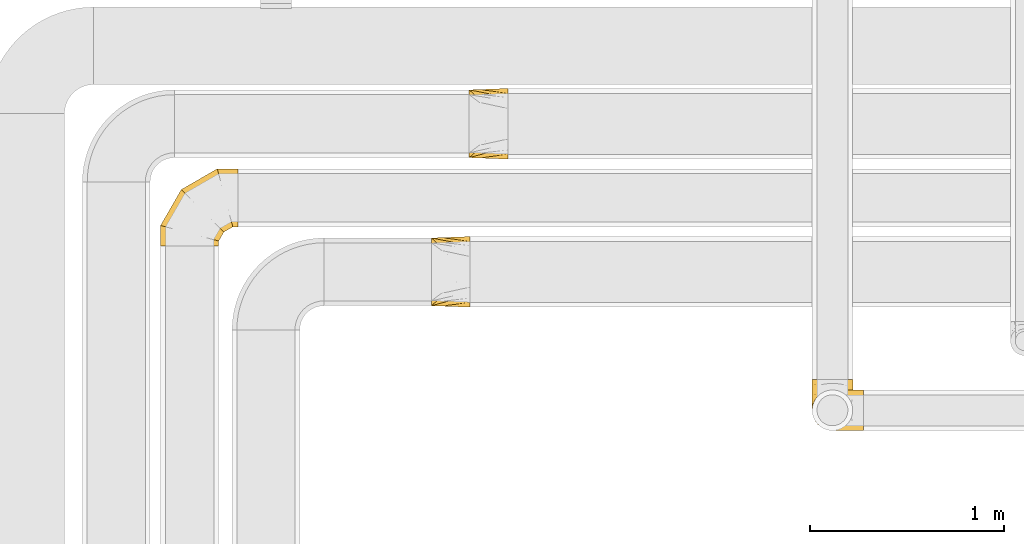
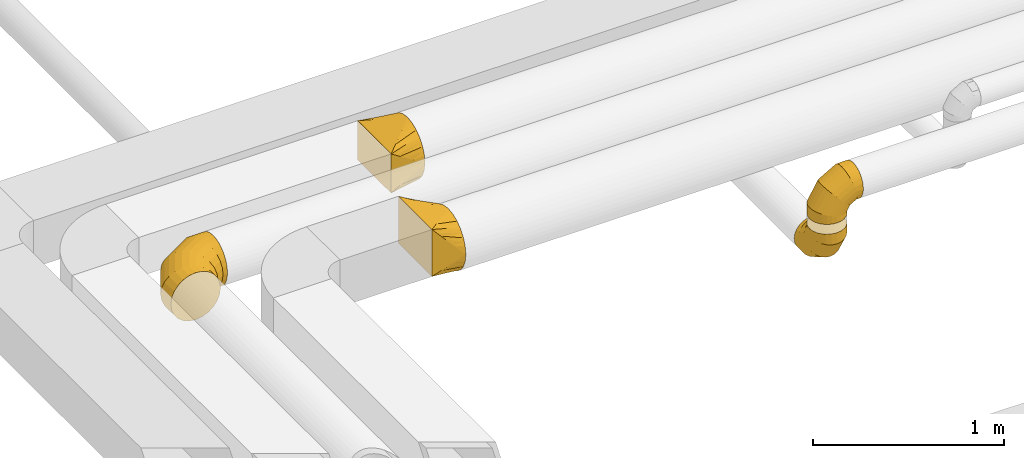
# One storey, part 11 of 92: 5 coverings.
"""IFC2X3 building model written with IfcOpenShell, lengths in millimetres."""

from ifc_helpers import new_model, entity, si_unit, converted_unit, derived_unit, direction, frame, origin, place, context, subcontext, project, spatial, faceted_brep, element, save


model = new_model("IFC2X3")

# Units and contexts
model_context = context("Model", 3, precision=0.01, world=origin(), true_north=direction((6.12303176911189e-17, 1.0)))
body_context = subcontext(model_context, "Body", "Model", "MODEL_VIEW")
ifc_project = project(units=[si_unit("LENGTHUNIT", "METRE", prefix="MILLI"), si_unit("AREAUNIT", "SQUARE_METRE"), si_unit("VOLUMEUNIT", "CUBIC_METRE"), converted_unit("PLANEANGLEUNIT", "DEGREE", entity("IfcRatioMeasure", 0.0174532925199433), si_unit("PLANEANGLEUNIT", "RADIAN"), dimensions=[0, 0, 0, 0, 0, 0, 0]), si_unit("MASSUNIT", "GRAM", prefix="KILO"), derived_unit("MASSDENSITYUNIT", [(si_unit("MASSUNIT", "GRAM", prefix="KILO"), 1), (si_unit("LENGTHUNIT", "METRE"), -3)]), derived_unit("MOMENTOFINERTIAUNIT", [(si_unit("LENGTHUNIT", "METRE"), 4)]), si_unit("TIMEUNIT", "SECOND"), si_unit("FREQUENCYUNIT", "HERTZ"), si_unit("THERMODYNAMICTEMPERATUREUNIT", "DEGREE_CELSIUS"), derived_unit("THERMALTRANSMITTANCEUNIT", [(si_unit("MASSUNIT", "GRAM", prefix="KILO"), 1), (si_unit("THERMODYNAMICTEMPERATUREUNIT", "KELVIN"), -1), (si_unit("TIMEUNIT", "SECOND"), -3)]), derived_unit("VOLUMETRICFLOWRATEUNIT", [(si_unit("LENGTHUNIT", "METRE"), 3), (si_unit("TIMEUNIT", "SECOND"), -1)]), derived_unit("MASSFLOWRATEUNIT", [(si_unit("MASSUNIT", "GRAM", prefix="KILO"), 1), (si_unit("TIMEUNIT", "SECOND"), -1)]), derived_unit("ROTATIONALFREQUENCYUNIT", [(si_unit("TIMEUNIT", "SECOND"), -1)]), si_unit("ELECTRICCURRENTUNIT", "AMPERE"), si_unit("ELECTRICVOLTAGEUNIT", "VOLT"), si_unit("POWERUNIT", "WATT"), si_unit("FORCEUNIT", "NEWTON", prefix="KILO"), si_unit("ILLUMINANCEUNIT", "LUX"), si_unit("LUMINOUSFLUXUNIT", "LUMEN"), si_unit("LUMINOUSINTENSITYUNIT", "CANDELA"), derived_unit("USERDEFINED", [(si_unit("MASSUNIT", "GRAM", prefix="KILO"), -1), (si_unit("LENGTHUNIT", "METRE"), -2), (si_unit("TIMEUNIT", "SECOND"), 3), (si_unit("LUMINOUSFLUXUNIT", "LUMEN"), 1)]), derived_unit("LINEARVELOCITYUNIT", [(si_unit("LENGTHUNIT", "METRE"), 1), (si_unit("TIMEUNIT", "SECOND"), -1)]), si_unit("PRESSUREUNIT", "PASCAL"), derived_unit("USERDEFINED", [(si_unit("LENGTHUNIT", "METRE"), -2), (si_unit("MASSUNIT", "GRAM", prefix="KILO"), 1), (si_unit("TIMEUNIT", "SECOND"), -2)]), derived_unit("LINEARFORCEUNIT", [(si_unit("MASSUNIT", "GRAM", prefix="KILO"), 1), (si_unit("LENGTHUNIT", "METRE"), 1), (si_unit("TIMEUNIT", "SECOND"), -2), (si_unit("LENGTHUNIT", "METRE"), -1)]), derived_unit("PLANARFORCEUNIT", [(si_unit("MASSUNIT", "GRAM", prefix="KILO"), 1), (si_unit("LENGTHUNIT", "METRE"), 1), (si_unit("TIMEUNIT", "SECOND"), -2), (si_unit("LENGTHUNIT", "METRE"), -2)])], contexts=[model_context])

# Site, building, storey
site_placement = place(None, origin())
site = spatial("IfcSite", under=ifc_project, at=site_placement, CompositionType="ELEMENT")
building_placement = place(site_placement, origin())
building = spatial("IfcBuilding", under=site, at=building_placement, CompositionType="ELEMENT")
storey_placement = place(building_placement, frame((0.0, 0.0, 4200.0)))
storey = spatial("IfcBuildingStorey", under=building, at=storey_placement, CompositionType="ELEMENT", Elevation=4200.0)

# Coverings
covering_1_placement = place(storey_placement, frame((25785.03, 14135.4, 2853.4)))
element("IfcCovering", 1, at=covering_1_placement, inside=storey, PredefinedType="INSULATION", context=body_context, shape_type="Brep", body=[
    faceted_brep([(1.6, 106.6, 266.6), (6.73, 74.15, 266.6), (21.65, 44.88, 266.6), (44.88, 21.65, 266.6), (74.15, 6.73, 266.6), (106.6, 1.6, 266.6), (139.04, 6.73, 266.6), (168.31, 21.65, 266.6), (191.54, 44.88, 266.6), (206.46, 74.15, 266.6), (211.6, 106.6, 266.6), (206.46, 139.04, 266.6), (191.54, 168.31, 266.6), (168.31, 191.54, 266.6), (139.04, 206.46, 266.6), (106.6, 211.6, 266.6), (74.15, 206.46, 266.6), (44.88, 191.54, 266.6), (21.65, 168.31, 266.6), (6.73, 139.04, 266.6), (159.1, 266.6, 15.66), (133.77, 266.6, 5.17), (106.6, 266.6, 1.6), (79.42, 266.6, 5.17), (54.1, 266.6, 15.66), (32.35, 266.6, 32.35), (15.66, 266.6, 54.1), (5.17, 266.6, 79.42), (1.6, 266.6, 106.6), (5.17, 266.6, 133.77), (15.66, 266.6, 159.1), (32.35, 266.6, 180.84), (54.1, 266.6, 197.53), (79.42, 266.6, 208.02), (106.6, 266.6, 211.6), (133.77, 266.6, 208.02), (159.1, 266.6, 197.53), (180.84, 266.6, 180.84), (197.53, 266.6, 159.1), (208.02, 266.6, 133.77), (211.6, 266.6, 106.6), (208.02, 266.6, 79.42), (197.53, 266.6, 54.1), (180.84, 266.6, 32.35), (106.6, 195.59, 1.6), (79.42, 196.55, 5.17), (54.1, 199.36, 15.66), (32.35, 203.83, 32.35), (15.66, 209.66, 54.1), (5.17, 216.44, 79.42), (1.6, 223.72, 106.6), (5.17, 231.01, 133.77), (15.66, 237.79, 159.1), (32.35, 243.62, 180.84), (54.1, 248.09, 197.53), (79.42, 250.9, 208.02), (106.6, 251.86, 211.6), (133.77, 250.9, 208.02), (159.1, 248.09, 197.53), (180.84, 243.62, 180.84), (208.02, 231.01, 133.77), (211.6, 223.72, 106.6), (197.53, 237.79, 159.1), (208.02, 216.44, 79.42), (197.53, 209.66, 54.1), (180.84, 203.83, 32.35), (159.1, 199.36, 15.66), (133.77, 196.55, 5.17), (106.6, 72.6, 72.6), (79.42, 75.22, 75.22), (54.1, 82.9, 82.9), (32.35, 95.12, 95.12), (15.66, 111.03, 111.03), (5.17, 129.57, 129.57), (1.6, 149.47, 149.47), (5.17, 169.36, 169.36), (15.66, 187.9, 187.9), (32.35, 203.82, 203.82), (54.1, 216.03, 216.03), (79.42, 223.71, 223.71), (106.6, 226.33, 226.33), (133.77, 223.71, 223.71), (159.1, 216.03, 216.03), (180.84, 203.82, 203.82), (208.02, 169.36, 169.36), (211.6, 149.47, 149.47), (197.53, 187.9, 187.9), (208.02, 129.57, 129.57), (197.53, 111.03, 111.03), (180.84, 95.12, 95.12), (159.1, 82.9, 82.9), (133.77, 75.22, 75.22), (106.6, 1.6, 195.59), (79.42, 5.17, 196.55), (54.1, 15.66, 199.36), (32.35, 32.35, 203.83), (15.66, 54.1, 209.66), (5.17, 79.42, 216.44), (1.6, 106.6, 223.72), (5.17, 133.77, 231.01), (15.66, 159.1, 237.79), (32.35, 180.84, 243.62), (54.1, 197.53, 248.09), (79.42, 208.02, 250.9), (106.6, 211.6, 251.86), (133.77, 208.02, 250.9), (159.1, 197.53, 248.09), (180.84, 180.84, 243.62), (208.02, 133.77, 231.01), (211.6, 106.6, 223.72), (197.53, 159.1, 237.79), (208.02, 79.42, 216.44), (197.53, 54.1, 209.66), (180.84, 32.35, 203.83), (159.1, 15.66, 199.36), (133.77, 5.17, 196.55)], [[[0, 1, 2, 3, 4, 5, 6, 7, 8, 9, 10, 11, 12, 13, 14, 15, 16, 17, 18, 19]], [[20, 21, 22, 23, 24, 25, 26, 27, 28, 29, 30, 31, 32, 33, 34, 35, 36, 37, 38, 39, 40, 41, 42, 43]], [[22, 44, 45, 23]], [[23, 45, 46, 24]], [[24, 46, 47, 25]], [[25, 47, 48, 26]], [[26, 48, 49, 27]], [[50, 28, 27, 49]], [[51, 52, 30, 29]], [[50, 51, 29, 28]], [[53, 31, 30, 52]], [[54, 55, 33, 32]], [[54, 32, 31, 53]], [[56, 34, 33, 55]], [[57, 58, 36, 35]], [[56, 57, 35, 34]], [[37, 36, 58, 59]], [[60, 61, 40, 39]], [[62, 60, 39, 38]], [[59, 62, 38, 37]], [[41, 40, 61, 63]], [[42, 41, 63, 64]], [[64, 65, 43, 42]], [[21, 20, 66, 67]], [[22, 21, 67, 44]], [[65, 66, 20, 43]], [[45, 44, 68, 69]], [[46, 45, 69, 70]], [[70, 71, 47, 46]], [[48, 47, 71, 72]], [[49, 48, 72, 73]], [[50, 49, 73, 74]], [[75, 76, 52, 51]], [[74, 75, 51, 50]], [[53, 52, 76, 77]], [[78, 79, 55, 54]], [[77, 78, 54, 53]], [[56, 55, 79, 80]], [[81, 82, 58, 57]], [[80, 81, 57, 56]], [[59, 58, 82, 83]], [[84, 85, 61, 60]], [[86, 84, 60, 62]], [[83, 86, 62, 59]], [[63, 61, 85, 87]], [[64, 63, 87, 88]], [[65, 64, 88, 89]], [[67, 66, 90, 91]], [[44, 67, 91, 68]], [[89, 90, 66, 65]], [[69, 68, 92, 93]], [[70, 69, 93, 94]], [[94, 95, 71, 70]], [[72, 71, 95, 96]], [[73, 72, 96, 97]], [[74, 73, 97, 98]], [[99, 100, 76, 75]], [[98, 99, 75, 74]], [[77, 76, 100, 101]], [[102, 103, 79, 78]], [[101, 102, 78, 77]], [[80, 79, 103, 104]], [[105, 106, 82, 81]], [[104, 105, 81, 80]], [[83, 82, 106, 107]], [[108, 109, 85, 84]], [[110, 108, 84, 86]], [[107, 110, 86, 83]], [[87, 85, 109, 111]], [[88, 87, 111, 112]], [[89, 88, 112, 113]], [[91, 90, 114, 115]], [[68, 91, 115, 92]], [[113, 114, 90, 89]], [[93, 5, 4]], [[94, 4, 3]], [[5, 93, 92]], [[93, 4, 94]], [[3, 95, 94]], [[96, 2, 1]], [[97, 1, 0]], [[95, 2, 96]], [[96, 1, 97]], [[0, 98, 97]], [[2, 95, 3]], [[99, 0, 19]], [[100, 19, 18]], [[99, 98, 0]], [[100, 99, 19]], [[18, 101, 100]], [[102, 17, 16]], [[103, 16, 15]], [[102, 101, 17]], [[104, 103, 15]], [[102, 16, 103]], [[17, 101, 18]], [[105, 15, 14]], [[106, 14, 13]], [[105, 104, 15]], [[106, 105, 14]], [[13, 107, 106]], [[110, 12, 11]], [[108, 11, 10]], [[110, 107, 12]], [[109, 108, 10]], [[110, 11, 108]], [[12, 107, 13]], [[9, 8, 112]], [[10, 9, 111]], [[10, 111, 109]], [[111, 9, 112]], [[8, 113, 112]], [[114, 7, 6]], [[115, 6, 5]], [[113, 7, 114]], [[115, 114, 6]], [[92, 115, 5]], [[7, 113, 8]]]),
])
covering_2_placement = place(storey_placement, frame((25785.03, 14135.4, 3182.7)))
element("IfcCovering", 2, at=covering_2_placement, inside=storey, PredefinedType="INSULATION", context=body_context, shape_type="Brep", body=[
    faceted_brep([(266.6, 211.6, 160.0), (266.6, 206.46, 192.45), (266.6, 191.54, 221.72), (266.6, 168.31, 244.95), (266.6, 139.04, 259.86), (266.6, 106.6, 265.0), (266.6, 74.15, 259.86), (266.6, 44.88, 244.95), (266.6, 21.65, 221.72), (266.6, 6.73, 192.45), (266.6, 1.6, 160.0), (266.6, 6.73, 127.55), (266.6, 21.65, 98.28), (266.6, 44.88, 75.05), (266.6, 74.15, 60.14), (266.6, 106.6, 55.0), (266.6, 139.04, 60.14), (266.6, 168.31, 75.05), (266.6, 191.54, 98.28), (266.6, 206.46, 127.55), (15.66, 54.1, 0.0), (5.17, 79.42, 0.0), (1.6, 106.6, 0.0), (5.17, 133.77, 0.0), (15.66, 159.1, 0.0), (32.35, 180.84, 0.0), (54.1, 197.53, 0.0), (79.42, 208.02, 0.0), (106.6, 211.6, 0.0), (133.77, 208.02, 0.0), (159.1, 197.53, 0.0), (180.84, 180.84, 0.0), (197.53, 159.1, 0.0), (208.02, 133.77, 0.0), (211.6, 106.6, 0.0), (208.02, 79.42, 0.0), (197.53, 54.1, 0.0), (180.84, 32.35, 0.0), (159.1, 15.66, 0.0), (133.77, 5.17, 0.0), (106.6, 1.6, 0.0), (79.42, 5.17, 0.0), (54.1, 15.66, 0.0), (32.35, 32.35, 0.0), (1.6, 106.6, 71.01), (5.17, 133.77, 70.05), (15.66, 159.1, 67.24), (32.35, 180.84, 62.77), (54.1, 197.53, 56.94), (79.42, 208.02, 50.15), (106.6, 211.6, 42.87), (133.77, 208.02, 35.59), (159.1, 197.53, 28.8), (180.84, 180.84, 22.98), (197.53, 159.1, 18.51), (208.02, 133.77, 15.7), (211.6, 106.6, 14.74), (208.02, 79.42, 15.7), (197.53, 54.1, 18.51), (180.84, 32.35, 22.98), (133.77, 5.17, 35.59), (106.6, 1.6, 42.87), (159.1, 15.66, 28.8), (79.42, 5.17, 50.15), (54.1, 15.66, 56.94), (32.35, 32.35, 62.77), (15.66, 54.1, 67.24), (5.17, 79.42, 70.05), (72.6, 106.6, 193.99), (75.22, 133.77, 191.37), (82.9, 159.1, 183.7), (95.12, 180.84, 171.48), (111.03, 197.53, 155.56), (129.57, 208.02, 137.02), (149.47, 211.6, 117.13), (169.36, 208.02, 97.23), (187.9, 197.53, 78.7), (203.82, 180.84, 62.78), (216.03, 159.1, 50.56), (223.71, 133.77, 42.88), (226.33, 106.6, 40.26), (223.71, 79.42, 42.88), (216.03, 54.1, 50.56), (203.82, 32.35, 62.78), (169.36, 5.17, 97.23), (149.47, 1.6, 117.13), (187.9, 15.66, 78.7), (129.57, 5.17, 137.02), (111.03, 15.66, 155.56), (95.12, 32.35, 171.48), (82.9, 54.1, 183.7), (75.22, 79.42, 191.37), (195.59, 106.6, 265.0), (196.55, 133.77, 261.42), (199.36, 159.1, 250.93), (203.83, 180.84, 234.25), (209.66, 197.53, 212.5), (216.44, 208.02, 187.18), (223.72, 211.6, 160.0), (231.01, 208.02, 132.82), (237.79, 197.53, 107.5), (243.62, 180.84, 85.75), (248.09, 159.1, 69.07), (250.9, 133.77, 58.58), (251.86, 106.6, 55.0), (250.9, 79.42, 58.58), (248.09, 54.1, 69.07), (243.62, 32.35, 85.75), (231.01, 5.17, 132.82), (223.72, 1.6, 160.0), (237.79, 15.66, 107.5), (216.44, 5.17, 187.18), (209.66, 15.66, 212.5), (203.83, 32.35, 234.25), (199.36, 54.1, 250.93), (196.55, 79.42, 261.42)], [[[0, 1, 2, 3, 4, 5, 6, 7, 8, 9, 10, 11, 12, 13, 14, 15, 16, 17, 18, 19]], [[20, 21, 22, 23, 24, 25, 26, 27, 28, 29, 30, 31, 32, 33, 34, 35, 36, 37, 38, 39, 40, 41, 42, 43]], [[22, 44, 45, 23]], [[23, 45, 46, 24]], [[24, 46, 47, 25]], [[25, 47, 48, 26]], [[26, 48, 49, 27]], [[50, 28, 27, 49]], [[51, 52, 30, 29]], [[50, 51, 29, 28]], [[53, 31, 30, 52]], [[54, 55, 33, 32]], [[54, 32, 31, 53]], [[56, 34, 33, 55]], [[57, 58, 36, 35]], [[56, 57, 35, 34]], [[37, 36, 58, 59]], [[60, 61, 40, 39]], [[62, 60, 39, 38]], [[59, 62, 38, 37]], [[41, 40, 61, 63]], [[42, 41, 63, 64]], [[64, 65, 43, 42]], [[21, 20, 66, 67]], [[22, 21, 67, 44]], [[65, 66, 20, 43]], [[45, 44, 68, 69]], [[46, 45, 69, 70]], [[70, 71, 47, 46]], [[48, 47, 71, 72]], [[49, 48, 72, 73]], [[50, 49, 73, 74]], [[75, 76, 52, 51]], [[74, 75, 51, 50]], [[53, 52, 76, 77]], [[78, 79, 55, 54]], [[77, 78, 54, 53]], [[56, 55, 79, 80]], [[81, 82, 58, 57]], [[80, 81, 57, 56]], [[59, 58, 82, 83]], [[84, 85, 61, 60]], [[86, 84, 60, 62]], [[83, 86, 62, 59]], [[63, 61, 85, 87]], [[64, 63, 87, 88]], [[65, 64, 88, 89]], [[67, 66, 90, 91]], [[44, 67, 91, 68]], [[89, 90, 66, 65]], [[69, 68, 92, 93]], [[70, 69, 93, 94]], [[94, 95, 71, 70]], [[72, 71, 95, 96]], [[73, 72, 96, 97]], [[74, 73, 97, 98]], [[99, 100, 76, 75]], [[98, 99, 75, 74]], [[77, 76, 100, 101]], [[102, 103, 79, 78]], [[101, 102, 78, 77]], [[80, 79, 103, 104]], [[105, 106, 82, 81]], [[104, 105, 81, 80]], [[83, 82, 106, 107]], [[108, 109, 85, 84]], [[110, 108, 84, 86]], [[107, 110, 86, 83]], [[87, 85, 109, 111]], [[88, 87, 111, 112]], [[89, 88, 112, 113]], [[91, 90, 114, 115]], [[68, 91, 115, 92]], [[113, 114, 90, 89]], [[93, 5, 4]], [[94, 4, 3]], [[5, 93, 92]], [[93, 4, 94]], [[3, 95, 94]], [[96, 2, 1]], [[97, 1, 0]], [[95, 2, 96]], [[96, 1, 97]], [[0, 98, 97]], [[2, 95, 3]], [[99, 0, 19]], [[100, 19, 18]], [[99, 98, 0]], [[100, 99, 19]], [[18, 101, 100]], [[102, 17, 16]], [[103, 16, 15]], [[102, 101, 17]], [[104, 103, 15]], [[102, 16, 103]], [[17, 101, 18]], [[105, 15, 14]], [[106, 14, 13]], [[105, 104, 15]], [[106, 105, 14]], [[13, 107, 106]], [[110, 12, 11]], [[108, 11, 10]], [[110, 107, 12]], [[109, 108, 10]], [[110, 11, 108]], [[12, 107, 13]], [[9, 8, 112]], [[10, 9, 111]], [[10, 111, 109]], [[111, 9, 112]], [[8, 113, 112]], [[114, 7, 6]], [[115, 6, 5]], [[113, 7, 114]], [[115, 114, 6]], [[92, 115, 5]], [[7, 113, 8]]]),
])
covering_3_placement = place(storey_placement, frame((24015.14, 15537.91, 3115.9)))
element("IfcCovering", 3, at=covering_3_placement, inside=storey, PredefinedType="INSULATION", context=body_context, shape_type="Brep", body=[
    faceted_brep([(200.0, 313.14, 313.14), (200.0, 294.24, 327.64), (200.0, 275.35, 342.14), (200.0, 253.34, 351.26), (200.0, 231.33, 360.38), (200.0, 216.46, 362.33), (200.0, 201.59, 364.29), (200.0, 184.1, 366.6), (200.0, 166.6, 364.29), (200.0, 151.73, 362.33), (200.0, 136.86, 360.38), (200.0, 114.85, 351.26), (200.0, 92.85, 342.14), (200.0, 73.95, 327.64), (200.0, 55.05, 313.14), (200.0, 40.55, 294.24), (200.0, 26.05, 275.35), (200.0, 16.93, 253.34), (200.0, 7.81, 231.33), (200.0, 5.86, 216.46), (200.0, 3.9, 201.59), (200.0, 1.6, 184.1), (200.0, 3.9, 166.6), (200.0, 5.86, 151.73), (200.0, 7.81, 136.86), (200.0, 16.93, 114.85), (200.0, 26.05, 92.85), (200.0, 40.55, 73.95), (200.0, 55.05, 55.05), (200.0, 73.95, 40.55), (200.0, 92.85, 26.05), (200.0, 114.85, 16.93), (200.0, 136.86, 7.81), (200.0, 151.73, 5.86), (200.0, 166.6, 3.9), (200.0, 184.1, 1.6), (200.0, 201.59, 3.9), (200.0, 216.46, 5.86), (200.0, 231.33, 7.81), (200.0, 253.34, 16.93), (200.0, 275.35, 26.05), (200.0, 294.24, 40.55), (200.0, 313.14, 55.05), (200.0, 327.64, 73.95), (200.0, 342.14, 92.85), (200.0, 351.26, 114.85), (200.0, 360.38, 136.86), (200.0, 362.33, 151.73), (200.0, 364.29, 166.6), (200.0, 366.6, 184.1), (200.0, 364.29, 201.59), (200.0, 362.33, 216.46), (200.0, 360.38, 231.33), (200.0, 351.26, 253.34), (200.0, 342.14, 275.35), (200.0, 327.64, 294.24), (0.0, 359.1, 309.1), (0.0, 359.1, 59.1), (0.0, 9.1, 59.1), (0.0, 9.1, 309.1), (128.09, 247.02, 22.27), (104.11, 268.0, 29.16), (78.09, 290.77, 36.65), (100.0, 332.1, 53.28), (26.03, 336.32, 51.61), (52.06, 361.05, 91.63), (26.03, 360.07, 75.36), (78.09, 362.02, 107.9), (104.11, 363.0, 124.17), (128.09, 363.9, 139.15), (176.03, 205.07, 8.49), (152.06, 226.05, 15.38), (152.06, 364.8, 154.13), (176.03, 365.7, 169.11), (52.06, 313.55, 44.13), (26.03, 360.07, 292.83), (52.06, 361.05, 276.56), (78.09, 362.02, 260.29), (104.11, 363.0, 244.02), (128.09, 363.9, 229.04), (152.06, 364.8, 214.06), (176.03, 365.7, 199.08), (100.0, 339.91, 307.1), (52.06, 313.55, 324.06), (26.03, 336.32, 316.58), (78.09, 290.77, 331.54), (104.11, 268.0, 339.03), (128.09, 247.02, 345.92), (152.06, 226.05, 352.81), (176.03, 205.07, 359.7), (26.03, 31.87, 316.58), (52.06, 54.65, 324.06), (78.09, 77.42, 331.54), (104.11, 100.2, 339.03), (128.09, 121.17, 345.92), (152.06, 142.15, 352.81), (176.03, 163.12, 359.7), (100.0, 36.1, 314.91), (52.06, 7.14, 276.56), (26.03, 8.12, 292.83), (78.09, 6.17, 260.29), (104.11, 5.19, 244.02), (128.09, 4.29, 229.04), (152.06, 3.39, 214.06), (176.03, 2.49, 199.08), (26.03, 8.12, 75.36), (52.06, 7.14, 91.63), (78.09, 6.17, 107.9), (104.11, 5.19, 124.17), (128.09, 4.29, 139.15), (152.06, 3.39, 154.13), (176.03, 2.49, 169.11), (100.0, 28.28, 61.1), (52.06, 54.65, 44.13), (26.03, 31.87, 51.61), (78.09, 77.42, 36.65), (104.11, 100.2, 29.16), (128.09, 121.17, 22.27), (152.06, 142.15, 15.38), (176.03, 163.12, 8.49)], [[[0, 1, 2, 3, 4, 5, 6, 7, 8, 9, 10, 11, 12, 13, 14, 15, 16, 17, 18, 19, 20, 21, 22, 23, 24, 25, 26, 27, 28, 29, 30, 31, 32, 33, 34, 35, 36, 37, 38, 39, 40, 41, 42, 43, 44, 45, 46, 47, 48, 49, 50, 51, 52, 53, 54, 55]], [[56, 57, 58, 59]], [[60, 61, 62, 39]], [[63, 41, 64]], [[43, 42, 63]], [[38, 60, 39]], [[39, 62, 40]], [[65, 44, 43]], [[43, 63, 66]], [[45, 67, 68, 69]], [[70, 71, 60, 38, 37, 36, 35]], [[47, 46, 69, 72, 73, 49, 48]], [[45, 44, 67]], [[45, 69, 46]], [[44, 65, 67]], [[41, 74, 64]], [[41, 40, 74]], [[57, 63, 64]], [[41, 63, 42]], [[43, 66, 65]], [[63, 57, 66]], [[62, 74, 40]], [[57, 56, 75, 76, 77, 78, 79, 80, 81, 49, 73, 72, 69, 68, 67, 65, 66]], [[79, 78, 77, 53]], [[82, 55, 75]], [[1, 0, 82]], [[52, 79, 53]], [[53, 77, 54]], [[83, 2, 1]], [[1, 82, 84]], [[3, 85, 86, 87]], [[81, 80, 79, 52, 51, 50, 49]], [[5, 4, 87, 88, 89, 7, 6]], [[3, 2, 85]], [[3, 87, 4]], [[2, 83, 85]], [[55, 76, 75]], [[55, 54, 76]], [[56, 82, 75]], [[55, 82, 0]], [[1, 84, 83]], [[82, 56, 84]], [[77, 76, 54]], [[56, 59, 90, 91, 92, 93, 94, 95, 96, 7, 89, 88, 87, 86, 85, 83, 84]], [[94, 93, 92, 11]], [[97, 13, 90]], [[15, 14, 97]], [[10, 94, 11]], [[11, 92, 12]], [[98, 16, 15]], [[15, 97, 99]], [[17, 100, 101, 102]], [[96, 95, 94, 10, 9, 8, 7]], [[19, 18, 102, 103, 104, 21, 20]], [[17, 16, 100]], [[17, 102, 18]], [[16, 98, 100]], [[13, 91, 90]], [[13, 12, 91]], [[59, 97, 90]], [[13, 97, 14]], [[15, 99, 98]], [[97, 59, 99]], [[92, 91, 12]], [[59, 58, 105, 106, 107, 108, 109, 110, 111, 21, 104, 103, 102, 101, 100, 98, 99]], [[109, 108, 107, 25]], [[112, 27, 105]], [[29, 28, 112]], [[24, 109, 25]], [[25, 107, 26]], [[113, 30, 29]], [[29, 112, 114]], [[31, 115, 116, 117]], [[111, 110, 109, 24, 23, 22, 21]], [[33, 32, 117, 118, 119, 35, 34]], [[31, 30, 115]], [[31, 117, 32]], [[30, 113, 115]], [[27, 106, 105]], [[27, 26, 106]], [[58, 112, 105]], [[27, 112, 28]], [[29, 114, 113]], [[112, 58, 114]], [[107, 106, 26]], [[58, 57, 64, 74, 62, 61, 60, 71, 70, 35, 119, 118, 117, 116, 115, 113, 114]]]),
])
covering_4_placement = place(storey_placement, frame((23819.73, 14772.9, 3065.9)))
element("IfcCovering", 4, at=covering_4_placement, inside=storey, PredefinedType="INSULATION", context=body_context, shape_type="Brep", body=[
    faceted_brep([(200.0, 275.35, 342.14), (200.0, 253.34, 351.26), (200.0, 231.33, 360.38), (200.0, 216.46, 362.33), (200.0, 201.59, 364.29), (200.0, 184.1, 366.6), (200.0, 166.6, 364.29), (200.0, 151.73, 362.33), (200.0, 136.86, 360.38), (200.0, 114.85, 351.26), (200.0, 92.85, 342.14), (200.0, 73.95, 327.64), (200.0, 55.05, 313.14), (200.0, 40.55, 294.24), (200.0, 26.05, 275.35), (200.0, 16.93, 253.34), (200.0, 7.81, 231.33), (200.0, 5.86, 216.46), (200.0, 3.9, 201.59), (200.0, 1.6, 184.1), (200.0, 3.9, 166.6), (200.0, 5.86, 151.73), (200.0, 7.81, 136.86), (200.0, 16.93, 114.85), (200.0, 26.05, 92.85), (200.0, 40.55, 73.95), (200.0, 55.05, 55.05), (200.0, 73.95, 40.55), (200.0, 92.85, 26.05), (200.0, 114.85, 16.93), (200.0, 136.86, 7.81), (200.0, 151.73, 5.86), (200.0, 166.6, 3.9), (200.0, 184.1, 1.6), (200.0, 201.59, 3.9), (200.0, 216.46, 5.86), (200.0, 231.33, 7.81), (200.0, 253.34, 16.93), (200.0, 275.35, 26.05), (200.0, 294.24, 40.55), (200.0, 313.14, 55.05), (200.0, 327.64, 73.95), (200.0, 342.14, 92.85), (200.0, 351.26, 114.85), (200.0, 360.38, 136.86), (200.0, 362.33, 151.73), (200.0, 364.29, 166.6), (200.0, 366.6, 184.1), (200.0, 364.29, 201.59), (200.0, 362.33, 216.46), (200.0, 360.38, 231.33), (200.0, 351.26, 253.34), (200.0, 342.14, 275.35), (200.0, 327.64, 294.24), (200.0, 313.14, 313.14), (200.0, 294.24, 327.64), (0.0, 359.1, 409.1), (0.0, 359.1, 109.1), (0.0, 9.1, 109.1), (0.0, 9.1, 409.1), (128.09, 247.02, 40.25), (104.11, 268.0, 53.13), (78.09, 290.77, 67.12), (100.0, 332.1, 78.28), (26.03, 336.32, 95.1), (52.06, 361.05, 128.62), (26.03, 360.07, 118.86), (78.09, 362.02, 138.38), (104.11, 363.0, 148.14), (128.09, 363.9, 157.13), (176.03, 205.07, 14.48), (152.06, 226.05, 27.36), (152.06, 364.8, 166.12), (176.03, 365.7, 175.11), (52.06, 313.55, 81.11), (26.03, 360.07, 379.81), (52.06, 361.05, 350.53), (78.09, 362.02, 321.25), (104.11, 363.0, 291.97), (128.09, 363.9, 265.0), (152.06, 364.8, 238.03), (176.03, 365.7, 211.06), (100.0, 339.91, 357.1), (52.06, 313.55, 398.03), (26.03, 336.32, 403.56), (78.09, 290.77, 392.5), (104.11, 268.0, 386.97), (128.09, 247.02, 381.88), (152.06, 226.05, 376.78), (176.03, 205.07, 371.69), (26.03, 31.87, 403.56), (52.06, 54.65, 398.03), (78.09, 77.42, 392.5), (104.11, 100.2, 386.97), (128.09, 121.17, 381.88), (152.06, 142.15, 376.78), (176.03, 163.12, 371.69), (100.0, 36.1, 364.91), (52.06, 7.14, 350.53), (26.03, 8.12, 379.81), (78.09, 6.17, 321.25), (104.11, 5.19, 291.97), (128.09, 4.29, 265.0), (152.06, 3.39, 238.03), (176.03, 2.49, 211.06), (26.03, 8.12, 118.86), (52.06, 7.14, 128.62), (78.09, 6.17, 138.38), (104.11, 5.19, 148.14), (128.09, 4.29, 157.13), (152.06, 3.39, 166.12), (176.03, 2.49, 175.11), (100.0, 28.28, 86.1), (52.06, 54.65, 81.11), (26.03, 31.87, 95.1), (78.09, 77.42, 67.12), (104.11, 100.2, 53.13), (128.09, 121.17, 40.25), (152.06, 142.15, 27.36), (176.03, 163.12, 14.48)], [[[0, 1, 2, 3, 4, 5, 6, 7, 8, 9, 10, 11, 12, 13, 14, 15, 16, 17, 18, 19, 20, 21, 22, 23, 24, 25, 26, 27, 28, 29, 30, 31, 32, 33, 34, 35, 36, 37, 38, 39, 40, 41, 42, 43, 44, 45, 46, 47, 48, 49, 50, 51, 52, 53, 54, 55]], [[56, 57, 58, 59]], [[60, 61, 62, 37]], [[63, 39, 64]], [[41, 40, 63]], [[36, 60, 37]], [[37, 62, 38]], [[65, 42, 41]], [[41, 63, 66]], [[43, 67, 68, 69]], [[70, 71, 60, 36, 35, 34, 33]], [[45, 44, 69, 72, 73, 47, 46]], [[43, 42, 67]], [[43, 69, 44]], [[42, 65, 67]], [[39, 74, 64]], [[39, 38, 74]], [[57, 63, 64]], [[39, 63, 40]], [[41, 66, 65]], [[63, 57, 66]], [[62, 74, 38]], [[57, 56, 75, 76, 77, 78, 79, 80, 81, 47, 73, 72, 69, 68, 67, 65, 66]], [[79, 78, 77, 51]], [[82, 53, 75]], [[55, 54, 82]], [[50, 79, 51]], [[51, 77, 52]], [[83, 0, 55]], [[55, 82, 84]], [[1, 85, 86, 87]], [[81, 80, 79, 50, 49, 48, 47]], [[3, 2, 87, 88, 89, 5, 4]], [[1, 0, 85]], [[1, 87, 2]], [[0, 83, 85]], [[53, 76, 75]], [[53, 52, 76]], [[56, 82, 75]], [[53, 82, 54]], [[55, 84, 83]], [[82, 56, 84]], [[77, 76, 52]], [[56, 59, 90, 91, 92, 93, 94, 95, 96, 5, 89, 88, 87, 86, 85, 83, 84]], [[94, 93, 92, 9]], [[97, 11, 90]], [[13, 12, 97]], [[8, 94, 9]], [[9, 92, 10]], [[98, 14, 13]], [[13, 97, 99]], [[15, 100, 101, 102]], [[96, 95, 94, 8, 7, 6, 5]], [[17, 16, 102, 103, 104, 19, 18]], [[15, 14, 100]], [[15, 102, 16]], [[14, 98, 100]], [[11, 91, 90]], [[11, 10, 91]], [[59, 97, 90]], [[11, 97, 12]], [[13, 99, 98]], [[97, 59, 99]], [[92, 91, 10]], [[104, 103, 102, 101, 100, 98, 99, 59, 58, 105, 106, 107, 108, 109, 110, 111, 19]], [[109, 108, 107, 23]], [[112, 25, 105]], [[27, 26, 112]], [[22, 109, 23]], [[23, 107, 24]], [[113, 28, 27]], [[27, 112, 114]], [[29, 115, 116, 117]], [[111, 110, 109, 22, 21, 20, 19]], [[31, 30, 117, 118, 119, 33, 32]], [[29, 28, 115]], [[29, 117, 30]], [[28, 113, 115]], [[25, 106, 105]], [[25, 24, 106]], [[58, 112, 105]], [[25, 112, 26]], [[27, 114, 113]], [[112, 58, 114]], [[107, 106, 24]], [[58, 57, 64, 74, 62, 61, 60, 71, 70, 33, 119, 118, 117, 116, 115, 113, 114]]]),
])
covering_5_placement = place(storey_placement, frame((22419.38, 15089.5, 3148.4)))
element("IfcCovering", 5, at=covering_5_placement, inside=storey, PredefinedType="INSULATION", context=body_context, shape_type="Brep", body=[
    faceted_brep([(45.53, 0.0, 257.66), (21.69, 0.0, 226.6), (6.71, 0.0, 190.42), (1.6, 0.0, 151.6), (6.71, 0.0, 112.77), (21.69, 0.0, 76.6), (45.53, 0.0, 45.53), (76.6, 0.0, 21.69), (112.77, 0.0, 6.71), (151.6, 0.0, 1.6), (190.42, 0.0, 6.71), (226.6, 0.0, 21.69), (257.66, 0.0, 45.53), (281.5, 0.0, 76.6), (296.48, 0.0, 112.77), (301.6, 0.0, 151.6), (296.48, 0.0, 190.42), (281.5, 0.0, 226.6), (257.66, 0.0, 257.66), (226.6, 0.0, 281.5), (190.42, 0.0, 296.48), (151.6, 0.0, 301.6), (112.77, 0.0, 296.48), (76.6, 0.0, 281.5), (401.6, 379.9, 76.6), (401.6, 394.89, 112.77), (401.6, 400.0, 151.6), (401.6, 394.89, 190.42), (401.6, 379.9, 226.6), (401.6, 356.07, 257.66), (401.6, 325.0, 281.5), (401.6, 288.82, 296.48), (401.6, 250.0, 301.6), (401.6, 211.18, 296.48), (401.6, 175.0, 281.5), (401.6, 143.93, 257.66), (401.6, 120.1, 226.6), (401.6, 105.11, 190.42), (401.6, 100.0, 151.6), (401.6, 105.11, 112.77), (401.6, 120.1, 76.6), (401.6, 143.93, 45.53), (401.6, 175.0, 21.69), (401.6, 211.18, 6.71), (401.6, 250.0, 1.6), (401.6, 288.82, 6.71), (401.6, 325.0, 21.69), (401.6, 356.07, 45.53), (294.42, 400.0, 151.6), (295.79, 394.89, 190.42), (299.8, 379.9, 226.6), (306.19, 356.07, 257.66), (314.51, 325.0, 281.5), (324.21, 288.82, 296.48), (334.61, 250.0, 301.6), (345.01, 211.18, 296.48), (354.7, 175.0, 281.5), (363.03, 143.93, 257.66), (369.42, 120.1, 226.6), (373.43, 105.11, 190.42), (374.8, 100.0, 151.6), (373.43, 105.11, 112.77), (369.42, 120.1, 76.6), (363.03, 143.93, 45.53), (345.01, 211.18, 6.71), (334.61, 250.0, 1.6), (354.7, 175.0, 21.69), (324.21, 288.82, 6.71), (314.51, 325.0, 21.69), (306.19, 356.07, 45.53), (299.8, 379.9, 76.6), (295.79, 394.89, 112.77), (108.77, 292.82, 151.6), (112.52, 289.08, 190.42), (123.49, 278.11, 226.6), (140.94, 260.66, 257.66), (163.68, 237.92, 281.5), (190.16, 211.43, 296.48), (218.58, 183.01, 301.6), (247.0, 154.59, 296.48), (273.49, 128.11, 281.5), (296.23, 105.37, 257.66), (313.68, 87.92, 226.6), (324.65, 76.95, 190.42), (328.39, 73.21, 151.6), (324.65, 76.95, 112.77), (313.68, 87.92, 76.6), (296.23, 105.37, 45.53), (247.0, 154.59, 6.71), (218.58, 183.01, 1.6), (273.49, 128.11, 21.69), (190.16, 211.43, 6.71), (163.68, 237.92, 21.69), (140.94, 260.66, 45.53), (123.49, 278.11, 76.6), (112.52, 289.08, 112.77), (1.6, 107.18, 151.6), (6.71, 105.81, 190.42), (21.69, 101.79, 226.6), (45.53, 95.41, 257.66), (76.6, 87.08, 281.5), (112.77, 77.39, 296.48), (151.6, 66.99, 301.6), (190.42, 56.58, 296.48), (226.6, 46.89, 281.5), (257.66, 38.57, 257.66), (281.5, 32.18, 226.6), (296.48, 28.16, 190.42), (301.6, 26.79, 151.6), (296.48, 28.16, 112.77), (281.5, 32.18, 76.6), (257.66, 38.57, 45.53), (190.42, 56.58, 6.71), (151.6, 66.99, 1.6), (226.6, 46.89, 21.69), (112.77, 77.39, 6.71), (76.6, 87.08, 21.69), (45.53, 95.41, 45.53), (21.69, 101.79, 76.6), (6.71, 105.81, 112.77)], [[[0, 1, 2, 3, 4, 5, 6, 7, 8, 9, 10, 11, 12, 13, 14, 15, 16, 17, 18, 19, 20, 21, 22, 23]], [[24, 25, 26, 27, 28, 29, 30, 31, 32, 33, 34, 35, 36, 37, 38, 39, 40, 41, 42, 43, 44, 45, 46, 47]], [[26, 48, 49, 27]], [[27, 49, 50, 28]], [[51, 29, 28, 50]], [[29, 51, 52, 30]], [[30, 52, 53, 31]], [[54, 32, 31, 53]], [[55, 56, 34, 33]], [[54, 55, 33, 32]], [[57, 35, 34, 56]], [[58, 59, 37, 36]], [[58, 36, 35, 57]], [[60, 38, 37, 59]], [[61, 62, 40, 39]], [[60, 61, 39, 38]], [[41, 40, 62, 63]], [[64, 65, 44, 43]], [[66, 64, 43, 42]], [[63, 66, 42, 41]], [[45, 44, 65, 67]], [[46, 45, 67, 68]], [[68, 69, 47, 46]], [[25, 24, 70, 71]], [[26, 25, 71, 48]], [[69, 70, 24, 47]], [[49, 48, 72, 73]], [[50, 49, 73, 74]], [[74, 75, 51, 50]], [[52, 51, 75, 76]], [[53, 52, 76, 77]], [[54, 53, 77, 78]], [[79, 80, 56, 55]], [[78, 79, 55, 54]], [[57, 56, 80, 81]], [[82, 83, 59, 58]], [[81, 82, 58, 57]], [[60, 59, 83, 84]], [[85, 86, 62, 61]], [[84, 85, 61, 60]], [[63, 62, 86, 87]], [[88, 89, 65, 64]], [[90, 88, 64, 66]], [[87, 90, 66, 63]], [[67, 65, 89, 91]], [[68, 67, 91, 92]], [[69, 68, 92, 93]], [[71, 70, 94, 95]], [[48, 71, 95, 72]], [[93, 94, 70, 69]], [[73, 72, 96, 97]], [[74, 73, 97, 98]], [[98, 99, 75, 74]], [[76, 75, 99, 100]], [[77, 76, 100, 101]], [[78, 77, 101, 102]], [[103, 104, 80, 79]], [[102, 103, 79, 78]], [[81, 80, 104, 105]], [[106, 107, 83, 82]], [[105, 106, 82, 81]], [[84, 83, 107, 108]], [[109, 110, 86, 85]], [[108, 109, 85, 84]], [[87, 86, 110, 111]], [[112, 113, 89, 88]], [[114, 112, 88, 90]], [[111, 114, 90, 87]], [[91, 89, 113, 115]], [[92, 91, 115, 116]], [[93, 92, 116, 117]], [[95, 94, 118, 119]], [[72, 95, 119, 96]], [[117, 118, 94, 93]], [[97, 96, 3, 2]], [[98, 97, 2, 1]], [[1, 0, 99, 98]], [[101, 100, 23, 22]], [[102, 101, 22, 21]], [[0, 23, 100, 99]], [[103, 102, 21, 20]], [[104, 103, 20, 19]], [[105, 104, 19, 18]], [[107, 106, 17, 16]], [[108, 107, 16, 15]], [[105, 18, 17, 106]], [[108, 15, 14, 109]], [[109, 14, 13, 110]], [[110, 13, 12, 111]], [[10, 9, 113, 112]], [[11, 10, 112, 114]], [[114, 111, 12, 11]], [[113, 9, 8, 115]], [[115, 8, 7, 116]], [[6, 117, 116, 7]], [[118, 5, 4, 119]], [[119, 4, 3, 96]], [[5, 118, 117, 6]]]),
])

save(model, "model.ifc")
